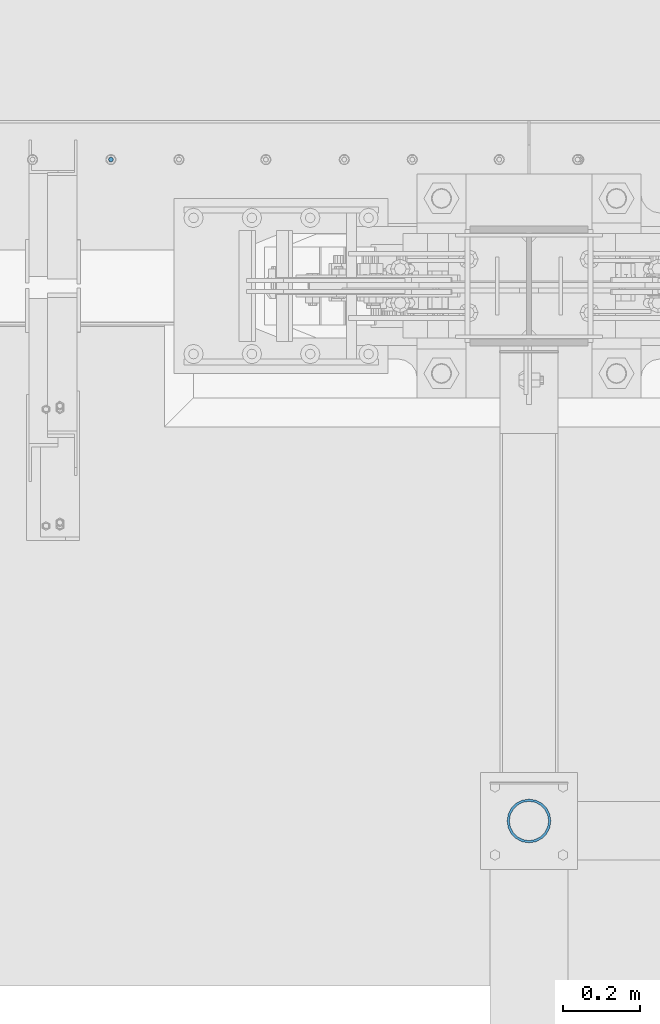
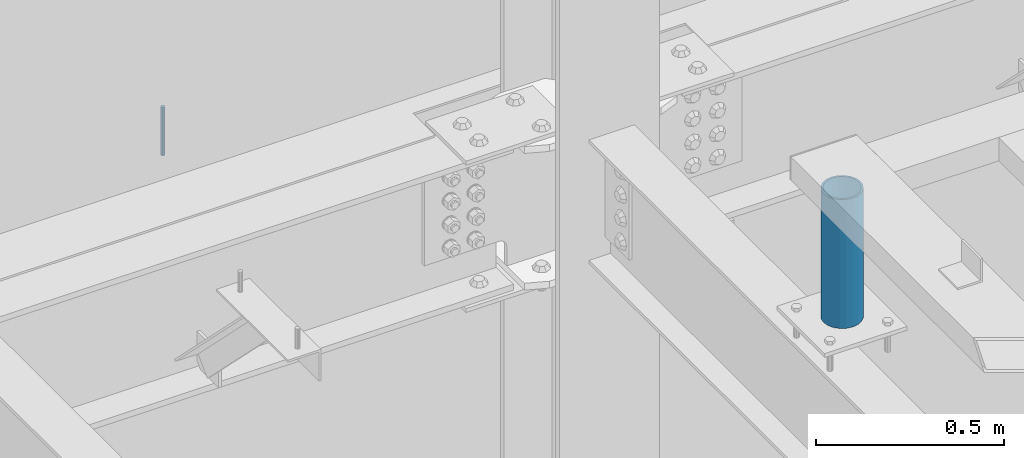
# One storey, part 525 of 1179: 2 columns, 2 elements without a shape of their own.
"""IFC2X3 building model written with IfcOpenShell, lengths in millimetres."""

from ifc_helpers import new_model, si_unit, frame, origin_with_axes, place, context, subcontext, project, spatial, faceted_brep, material, type_object, element, aggregate, save


model = new_model("IFC2X3")

# Units and contexts
model_context = context("Model", 3, precision=1e-05, world=origin_with_axes())
body_context = subcontext(model_context, "Body", "Model", "MODEL_VIEW")
ifc_project = project(units=[si_unit("LENGTHUNIT", "METRE", prefix="MILLI"), si_unit("AREAUNIT", "SQUARE_METRE"), si_unit("VOLUMEUNIT", "CUBIC_METRE"), si_unit("MASSUNIT", "GRAM", prefix="KILO"), si_unit("TIMEUNIT", "SECOND"), si_unit("PLANEANGLEUNIT", "RADIAN"), si_unit("SOLIDANGLEUNIT", "STERADIAN"), si_unit("THERMODYNAMICTEMPERATUREUNIT", "DEGREE_CELSIUS"), si_unit("LUMINOUSINTENSITYUNIT", "LUMEN")], contexts=[model_context])

# Site, building, storey
site_placement = place(None, origin_with_axes())
site = spatial("IfcSite", under=ifc_project, at=site_placement, CompositionType="ELEMENT")
building_placement = place(site_placement, origin_with_axes())
building = spatial("IfcBuilding", under=site, at=building_placement, Name="Undefined", CompositionType="ELEMENT")
storey_placement = place(building_placement, origin_with_axes())
storey = spatial("IfcBuildingStorey", under=building, at=storey_placement, Name="Undefined", CompositionType="ELEMENT", Elevation=0.0)

# Assembly, column
assembly_1_placement = place(storey_placement, origin_with_axes())
assembly_1 = element("IfcElementAssembly", 1, at=assembly_1_placement, inside=storey, Name="BEAM", AssemblyPlace="NOTDEFINED", PredefinedType="RIGID_FRAME")
ifc_material_1 = material(Name="STEEL/A307")
column_type_1 = type_object("IfcColumnType", PredefinedType="NOTDEFINED")
column_1_placement = place(assembly_1_placement, frame((7188.2, 41529.0, 13125.45), z_axis=(0.0, 1.0, 0.0), x_axis=(0.0, 0.0, 1.0)))
column_1 = element("IfcColumn", 2, at=column_1_placement, type_object=column_type_1, material=ifc_material_1, Name="THREADED ROD", context=body_context, shape_type="Brep", body=[
    faceted_brep([(0.0, -6.34999999999854, 0.0), (0.0, -4.49012806053361, -4.49012806053452), (157.162499999999, -4.49012806053361, -4.49012806053361), (157.162499999999, -6.34999999999854, 0.0), (0.0, 0.0, -6.34999999999991), (157.162499999999, 0.0, -6.34999999999854), (0.0, 4.49012806053361, -4.49012806053452), (157.162499999999, 4.49012806053361, -4.49012806053361), (0.0, 6.34999999999854, 0.0), (157.162499999999, 6.34999999999854, 0.0), (0.0, 4.49012806053361, 4.49012806053452), (157.162499999999, 4.49012806053361, 4.49012806053361), (0.0, 0.0, 6.34999999999991), (157.162499999999, 0.0, 6.34999999999854), (0.0, -4.49012806053361, 4.49012806053452), (157.162499999999, -4.49012806053361, 4.49012806053361)], [[[0, 1, 2, 3]], [[1, 4, 5, 2]], [[4, 6, 7, 5]], [[6, 8, 9, 7]], [[8, 10, 11, 9]], [[10, 12, 13, 11]], [[12, 14, 15, 13]], [[14, 0, 3, 15]], [[5, 7, 9, 11, 13, 15, 3, 2]], [[14, 12, 10, 8, 6, 4, 1, 0]]]),
])
aggregate(assembly_1, [column_1])

assembly_2_placement = place(storey_placement, origin_with_axes())
assembly_2 = element("IfcElementAssembly", 3, at=assembly_2_placement, inside=storey, Name="FRAME", AssemblyPlace="NOTDEFINED", PredefinedType="RIGID_FRAME")
ifc_material_2 = material()
column_type_2 = type_object("IfcColumnType", Name="PIPE4SCH40", PredefinedType="NOTDEFINED")
column_2_placement = place(assembly_2_placement, frame((8280.4, 39801.1344873485, 13265.15), z_axis=(0.0, 1.0, 0.0), x_axis=(0.0, 0.0, 1.0)))
column_2 = element("IfcColumn", 4, at=column_2_placement, type_object=column_type_2, material=ifc_material_2, Name="COLUMN", ObjectType="PIPE4SCH40", context=body_context, shape_type="Brep", body=[
    faceted_brep([(0.0, -51.1301999999996, 0.0), (0.0, -48.6277098894752, 15.8001007257917), (419.099999999999, -48.6277098894752, 15.8001007257917), (419.099999999999, -51.1301999999996, 0.0), (0.0, -41.3652007257915, 30.0535775067619), (419.099999999999, -41.3652007257915, 30.0535775067619), (0.0, -30.0535775067656, 41.3652007257915), (419.099999999999, -30.0535775067656, 41.3652007257915), (0.0, -15.8001007257917, 48.6277098894716), (419.099999999999, -15.8001007257917, 48.6277098894716), (0.0, 0.0, 51.1301999999996), (419.099999999999, 0.0, 51.1301999999996), (0.0, 15.8001007257917, 48.6277098894716), (419.099999999999, 15.8001007257917, 48.6277098894716), (0.0, 30.0535775067656, 41.3652007257915), (419.099999999999, 30.0535775067656, 41.3652007257915), (0.0, 41.3652007257915, 30.0535775067619), (419.099999999999, 41.3652007257915, 30.0535775067619), (0.0, 48.6277098894752, 15.8001007257917), (419.099999999999, 48.6277098894752, 15.8001007257917), (0.0, 51.1301999999996, 0.0), (419.099999999999, 51.1301999999996, 0.0), (0.0, 48.6277098894752, -15.8001007257917), (419.099999999999, 48.6277098894752, -15.8001007257917), (0.0, 41.3652007257915, -30.0535775067619), (419.099999999999, 41.3652007257915, -30.0535775067619), (0.0, 30.0535775067656, -41.3652007257915), (419.099999999999, 30.0535775067656, -41.3652007257915), (0.0, 15.8001007257917, -48.6277098894716), (419.099999999999, 15.8001007257917, -48.6277098894716), (0.0, 0.0, -51.1301999999996), (419.099999999999, 0.0, -51.1301999999996), (0.0, -15.8001007257917, -48.6277098894716), (419.099999999999, -15.8001007257917, -48.6277098894716), (0.0, -30.0535775067656, -41.3652007257915), (419.099999999999, -30.0535775067656, -41.3652007257915), (0.0, -41.3652007257915, -30.0535775067619), (419.099999999999, -41.3652007257915, -30.0535775067619), (0.0, -48.6277098894752, -15.8001007257917), (419.099999999999, -48.6277098894752, -15.8001007257917), (0.0, -57.1500000000015, 0.0), (0.0, -54.3528799062697, -17.6603212285263), (419.099999999999, -54.3528799062697, -17.6603212285263), (419.099999999999, -57.1500000000015, 0.0), (0.0, -46.235321228527, -33.5919271685125), (419.099999999999, -46.235321228527, -33.5919271685125), (0.0, -33.5919271685161, -46.2353212285307), (419.099999999999, -33.5919271685161, -46.2353212285307), (0.0, -17.6603212285299, -54.3528799062697), (419.099999999999, -17.6603212285299, -54.3528799062697), (0.0, 0.0, -57.1500000000015), (419.099999999999, 0.0, -57.1500000000015), (0.0, 17.6603212285299, -54.3528799062697), (419.099999999999, 17.6603212285299, -54.3528799062697), (0.0, 33.5919271685161, -46.2353212285307), (419.099999999999, 33.5919271685161, -46.2353212285307), (0.0, 46.235321228527, -33.5919271685125), (419.099999999999, 46.235321228527, -33.5919271685125), (0.0, 54.3528799062697, -17.6603212285263), (419.099999999999, 54.3528799062697, -17.6603212285263), (0.0, 57.1500000000015, 0.0), (419.099999999999, 57.1500000000015, 0.0), (0.0, 54.3528799062697, 17.6603212285263), (419.099999999999, 54.3528799062697, 17.6603212285263), (0.0, 46.235321228527, 33.5919271685125), (419.099999999999, 46.235321228527, 33.5919271685125), (0.0, 33.5919271685161, 46.2353212285307), (419.099999999999, 33.5919271685161, 46.2353212285307), (0.0, 17.6603212285299, 54.3528799062697), (419.099999999999, 17.6603212285299, 54.3528799062697), (0.0, 0.0, 57.1500000000015), (419.099999999999, 0.0, 57.1500000000015), (0.0, -17.6603212285299, 54.3528799062697), (419.099999999999, -17.6603212285299, 54.3528799062697), (0.0, -33.5919271685161, 46.2353212285307), (419.099999999999, -33.5919271685161, 46.2353212285307), (0.0, -46.235321228527, 33.5919271685125), (419.099999999999, -46.235321228527, 33.5919271685125), (0.0, -54.3528799062697, 17.6603212285263), (419.099999999999, -54.3528799062697, 17.6603212285263)], [[[0, 1, 2, 3]], [[1, 4, 5, 2]], [[4, 6, 7, 5]], [[6, 8, 9, 7]], [[8, 10, 11, 9]], [[10, 12, 13, 11]], [[12, 14, 15, 13]], [[14, 16, 17, 15]], [[16, 18, 19, 17]], [[18, 20, 21, 19]], [[20, 22, 23, 21]], [[22, 24, 25, 23]], [[24, 26, 27, 25]], [[26, 28, 29, 27]], [[28, 30, 31, 29]], [[30, 32, 33, 31]], [[32, 34, 35, 33]], [[34, 36, 37, 35]], [[36, 38, 39, 37]], [[38, 0, 3, 39]], [[40, 41, 42, 43]], [[41, 44, 45, 42]], [[44, 46, 47, 45]], [[46, 48, 49, 47]], [[48, 50, 51, 49]], [[50, 52, 53, 51]], [[52, 54, 55, 53]], [[54, 56, 57, 55]], [[56, 58, 59, 57]], [[58, 60, 61, 59]], [[60, 62, 63, 61]], [[62, 64, 65, 63]], [[64, 66, 67, 65]], [[66, 68, 69, 67]], [[68, 70, 71, 69]], [[70, 72, 73, 71]], [[72, 74, 75, 73]], [[74, 76, 77, 75]], [[76, 78, 79, 77]], [[78, 40, 43, 79]], [[45, 47, 49, 51, 53, 55, 57, 59, 61, 63, 65, 67, 69, 71, 73, 75, 77, 79, 43, 42], [5, 7, 9, 11, 13, 15, 17, 19, 21, 23, 25, 27, 29, 31, 33, 35, 37, 39, 3, 2]], [[78, 76, 74, 72, 70, 68, 66, 64, 62, 60, 58, 56, 54, 52, 50, 48, 46, 44, 41, 40], [38, 36, 34, 32, 30, 28, 26, 24, 22, 20, 18, 16, 14, 12, 10, 8, 6, 4, 1, 0]]]),
])
aggregate(assembly_2, [column_2])

save(model, "model.ifc")
